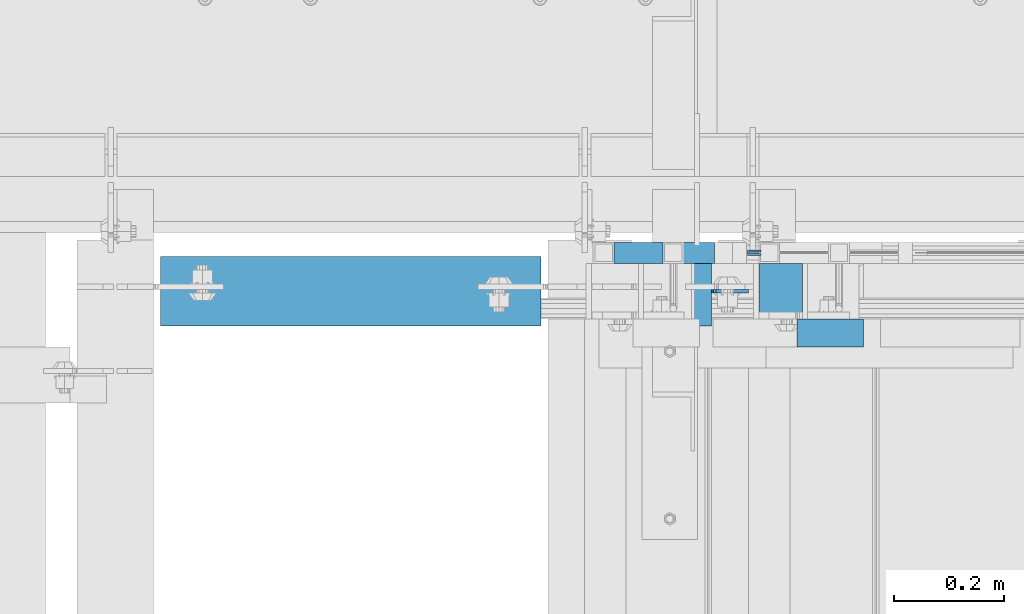
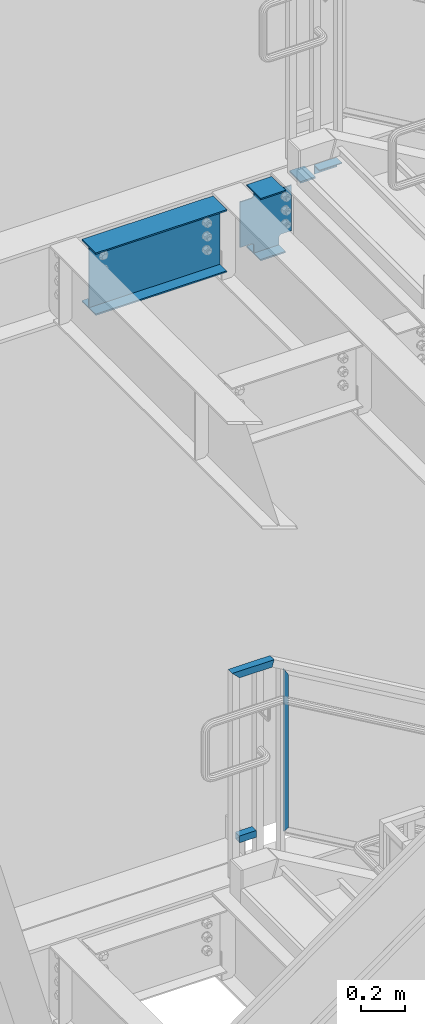
# One storey, part 934 of 1179: 5 beams, 2 members, 4 elements without a shape of their own.
"""IFC2X3 building model written with IfcOpenShell, lengths in millimetres."""

import ifcopenshell
import ifcopenshell.guid

model = None  # the IFC model being written
_history = None  # IfcOwnerHistory: only IFC2X3 demands one
_inside = {}  # id of a spatial element -> (the spatial element, [elements in it])
_under = {}  # id of a project, library or spatial element -> (it, [spatial elements below it])
_declared = {}  # id of a project -> (the project, [libraries it declares])
_typed = {}  # id of a type object -> (the type object, [elements of that type])
_made_of = {}  # id of a material, layer set ... -> (it, [elements and type objects made of it])


def new_model(schema):
    """Start an empty IFC model of exactly this schema.

    Asked for "IFC4X3", IfcOpenShell would pick the latest addendum, in which some entities
    have other attributes; the version numbers below select the first issue.
    IFC2X3 requires an IfcOwnerHistory on every rooted entity: one is made here for all.
    """
    global model, _history
    if schema == "IFC4X3":
        model = ifcopenshell.file(schema_version=(4, 3, 0, 0))
    else:
        model = ifcopenshell.file(schema=schema)
    _inside.clear()
    _under.clear()
    _declared.clear()
    _typed.clear()
    _made_of.clear()
    _history = None
    if model.schema == "IFC2X3":
        org = make("IfcOrganization", Name="unknown")
        user = make(
            "IfcPersonAndOrganization",
            ThePerson=make("IfcPerson", FamilyName="unknown"),
            TheOrganization=org,
        )
        app = make(
            "IfcApplication",
            ApplicationDeveloper=org,
            Version="unknown",
            ApplicationFullName="unknown",
            ApplicationIdentifier="unknown",
        )
        _history = make(
            "IfcOwnerHistory",
            OwningUser=user,
            OwningApplication=app,
            ChangeAction="ADDED",
            CreationDate=0,
        )
    return model


def make(cls, **values):
    """One entity of the class cls with the attributes given. An attribute that is None is left unset."""
    return model.create_entity(
        cls, **{name: value for name, value in values.items() if value is not None}
    )


def rooted(cls, **values):
    """An entity with a GlobalId (a new one), such as an element, a storey or a relation."""
    return make(cls, GlobalId=ifcopenshell.guid.new(), OwnerHistory=_history, **values)


def si_unit(unit_type, name, prefix=None):
    """IfcSIUnit, for example si_unit("LENGTHUNIT", "METRE", prefix="MILLI")."""
    return make("IfcSIUnit", UnitType=unit_type, Prefix=prefix, Name=name)


def assignment(units):
    """IfcUnitAssignment: the units of a project."""
    return None if units is None else make("IfcUnitAssignment", Units=units)


def point(xyz):
    """IfcCartesianPoint."""
    return None if xyz is None else make("IfcCartesianPoint", Coordinates=xyz)


def direction(xyz):
    """IfcDirection."""
    return None if xyz is None else make("IfcDirection", DirectionRatios=xyz)


def frame(location, z_axis=None, x_axis=None):
    """IfcAxis2Placement3D, a coordinate frame: its origin and axes. An axis left out is left unset."""
    return make(
        "IfcAxis2Placement3D",
        Location=point(location),
        Axis=direction(z_axis),
        RefDirection=direction(x_axis),
    )


def origin_with_axes():
    """The frame at (0, 0, 0) with the z axis (0, 0, 1) and the x axis (1, 0, 0) written out."""
    return frame((0.0, 0.0, 0.0), z_axis=(0.0, 0.0, 1.0), x_axis=(1.0, 0.0, 0.0))


def place(relative_to, where):
    """IfcLocalPlacement: puts the frame where relative to a parent placement (None: the world)."""
    return make(
        "IfcLocalPlacement", PlacementRelTo=relative_to, RelativePlacement=where
    )


def context(
    kind, dimensions, precision=None, world=None, true_north=None, identifier=None
):
    """IfcGeometricRepresentationContext, for example the 3D "Model" context."""
    return make(
        "IfcGeometricRepresentationContext",
        ContextIdentifier=identifier,
        ContextType=kind,
        CoordinateSpaceDimension=dimensions,
        Precision=precision,
        WorldCoordinateSystem=world,
        TrueNorth=true_north,
    )


def subcontext(parent, identifier, kind, view, scale=None):
    """IfcGeometricRepresentationSubContext, for example "Body" below "Model"."""
    return make(
        "IfcGeometricRepresentationSubContext",
        ContextIdentifier=identifier,
        ContextType=kind,
        ParentContext=parent,
        TargetScale=scale,
        TargetView=view,
    )


def project(units=None, contexts=None):
    """IfcProject with its units and contexts."""
    return rooted(
        "IfcProject",
        Name="project",
        RepresentationContexts=contexts,
        UnitsInContext=assignment(units),
    )


def spatial(cls, under=None, at=None, **own):
    """A site, building, storey or space (cls), placed at a placement, below another one or the project."""
    s = rooted(cls, ObjectPlacement=at, **own)
    if under is not None:
        _under.setdefault(under.id(), (under, []))[1].append(s)
    return s


def faces_of(points, faces, orient=None, outer=None):
    """IfcFace entities. A face is a list of loops; a loop is a list of indices into points, from 0.

    orient and outer hold one flag for each loop. By default every Orientation is true, the
    first loop of a face is its IfcFaceOuterBound and the others are IfcFaceBound.
    """
    made = []
    for i, loops in enumerate(faces):
        bounds = []
        for j, loop in enumerate(loops):
            is_outer = j == 0 if outer is None else outer[i][j]
            bounds.append(
                make(
                    "IfcFaceOuterBound" if is_outer else "IfcFaceBound",
                    Bound=make("IfcPolyLoop", Polygon=[points[k] for k in loop]),
                    Orientation=True if orient is None else orient[i][j],
                )
            )
        made.append(make("IfcFace", Bounds=bounds))
    return made


def faceted_brep(points, faces, orient=None, outer=None, voids=None):
    """IfcFacetedBrep: a solid bounded by flat faces; with voids (closed shells), ...WithVoids."""
    shared = [point(p) for p in points]
    hull = make("IfcClosedShell", CfsFaces=faces_of(shared, faces, orient, outer))
    if voids is None:
        return make("IfcFacetedBrep", Outer=hull)
    return make(
        "IfcFacetedBrepWithVoids",
        Outer=hull,
        Voids=[
            make(cls, CfsFaces=faces_of(shared, fs, o, b)) for cls, fs, o, b in voids
        ],
    )


def shape(context_of_items, identifier, shape_type, items):
    """IfcShapeRepresentation: the items that make up one representation, for example the "Body"."""
    return make(
        "IfcShapeRepresentation",
        ContextOfItems=context_of_items,
        RepresentationIdentifier=identifier,
        RepresentationType=shape_type,
        Items=items,
    )


def material(Name=None, Category=None):
    """IfcMaterial."""
    return make("IfcMaterial", Name=Name, Category=Category)


def made_of(thing, what):
    """Note that an element or type object is made of a material, layer set ...; save() writes the relation."""
    if what is not None:
        _made_of.setdefault(what.id(), (what, []))[1].append(thing)
    return thing


def type_object(cls, material=None, **own):
    """A type object (cls), such as IfcWallType, which elements share."""
    return made_of(rooted(cls, **own), material)


def element(
    cls,
    number,
    at=None,
    inside=None,
    cuts=None,
    type_object=None,
    material=None,
    context=None,
    identifier="Body",
    shape_type=None,
    held_by="IfcProductDefinitionShape",
    body=None,
    shapes=None,
    **own,
):
    """One element of the class cls, such as IfcWall. Its Tag is "e" and its number.

    at: its placement. inside: the storey or other place that contains it. cuts: it is an
    opening in that element (IfcRelVoidsElement). A single representation is given by context,
    identifier, shape_type and body (its items); several are given by shapes. held_by: the class
    of the entity that holds the representations. save() writes the other relations.
    """
    e = rooted(cls, Tag="e%d" % number, ObjectPlacement=at, **own)
    if body is not None:
        shapes = [shape(context, identifier, shape_type, body)]
    if shapes is not None:
        e.Representation = make(held_by, Representations=shapes)
    if inside is not None:
        _inside.setdefault(inside.id(), (inside, []))[1].append(e)
    if cuts is not None:
        rooted(
            "IfcRelVoidsElement", RelatingBuildingElement=cuts, RelatedOpeningElement=e
        )
    if type_object is not None:
        _typed.setdefault(type_object.id(), (type_object, []))[1].append(e)
    return made_of(e, material)


def aggregate(whole, parts):
    """IfcRelAggregates: a whole, such as a stair, and the parts it consists of."""
    return rooted("IfcRelAggregates", RelatingObject=whole, RelatedObjects=parts)


def save(model, path):
    """Write the relations noted so far, then the file.

    IfcRelAggregates (storeys below a building ...), IfcRelContainedInSpatialStructure (elements
    in a storey), IfcRelDefinesByType, IfcRelAssociatesMaterial and IfcRelDeclares: one each for
    every whole, place, type object, material and project.
    """
    for whole, parts in _under.values():
        aggregate(whole, parts)
    for where, things in _inside.values():
        rooted(
            "IfcRelContainedInSpatialStructure",
            RelatedElements=things,
            RelatingStructure=where,
        )
    for kind, things in _typed.values():
        rooted("IfcRelDefinesByType", RelatedObjects=things, RelatingType=kind)
    for what, things in _made_of.values():
        rooted("IfcRelAssociatesMaterial", RelatedObjects=things, RelatingMaterial=what)
    for by, libraries in _declared.values():
        rooted("IfcRelDeclares", RelatingContext=by, RelatedDefinitions=libraries)
    model.write(path)


model = new_model("IFC2X3")

# Units and contexts
model_context = context("Model", 3, precision=1e-05, world=origin_with_axes())
body_context = subcontext(model_context, "Body", "Model", "MODEL_VIEW")
ifc_project = project(units=[si_unit("LENGTHUNIT", "METRE", prefix="MILLI"), si_unit("AREAUNIT", "SQUARE_METRE"), si_unit("VOLUMEUNIT", "CUBIC_METRE"), si_unit("MASSUNIT", "GRAM", prefix="KILO"), si_unit("TIMEUNIT", "SECOND"), si_unit("PLANEANGLEUNIT", "RADIAN"), si_unit("SOLIDANGLEUNIT", "STERADIAN"), si_unit("THERMODYNAMICTEMPERATUREUNIT", "DEGREE_CELSIUS"), si_unit("LUMINOUSINTENSITYUNIT", "LUMEN")], contexts=[model_context])

# Site, building, storey
site_placement = place(None, origin_with_axes())
site = spatial("IfcSite", under=ifc_project, at=site_placement, CompositionType="ELEMENT")
building_placement = place(site_placement, origin_with_axes())
building = spatial("IfcBuilding", under=site, at=building_placement, Name="Undefined", CompositionType="ELEMENT")
storey_placement = place(building_placement, origin_with_axes())
storey = spatial("IfcBuildingStorey", under=building, at=storey_placement, Name="Undefined", CompositionType="ELEMENT", Elevation=0.0)

# Assembly, beam, members
assembly_1_placement = place(storey_placement, origin_with_axes())
assembly_1 = element("IfcElementAssembly", 1, at=assembly_1_placement, inside=storey, Name="GUARDRAIL", AssemblyPlace="NOTDEFINED", PredefinedType="RIGID_FRAME")
ifc_material_1 = material(Name="STEEL/BUY-OUT")
beam_type_1 = type_object("IfcBeamType", PredefinedType="NOTDEFINED")
beam_1_placement = place(assembly_1_placement, frame((19591.0331071758, 41062.2751647691, 4786.47180551808), z_axis=(0.0, 0.0, -1.0), x_axis=(-1.0, 0.0, 0.0)))
beam_1 = element("IfcBeam", 2, at=beam_1_placement, type_object=beam_type_1, material=ifc_material_1, Name="U-EDGE", context=body_context, shape_type="Brep", body=[
    faceted_brep([(2.91038304567337e-11, 7.9375, 440.175302877862), (25.3999999999687, 7.9375, 454.819), (25.400000000016, 7.9375, -454.819), (2.91038304567337e-11, 7.9375, -410.76229705665), (2.91038304567337e-11, 4.76249999999709, 440.175302877862), (2.91038304567337e-11, 4.76249999999709, -410.76229705665), (22.2250000000131, 4.76249999999709, 452.988538277322), (22.2250000000131, 4.76249999999709, -449.311912132071), (22.2250000000131, 1.58750000000146, 452.988538277322), (22.2250000000131, 1.58750000000146, -449.311912132071), (0.0, 1.58750000000146, 440.175302877845), (0.0, 1.58750000000146, -410.7622970566), (0.0, -1.58750000000146, 440.175302877845), (0.0, -1.58750000000146, -410.7622970566), (25.3999999999687, -1.58750000000146, 454.819), (25.400000000016, -1.58750000000146, -454.819)], [[[0, 1, 2, 3]], [[4, 0, 3, 5]], [[6, 4, 5, 7]], [[8, 6, 7, 9]], [[10, 8, 9, 11]], [[12, 10, 11, 13]], [[14, 12, 13, 15]], [[11, 9, 7, 5, 3, 2, 15, 13]], [[1, 14, 15, 2]], [[0, 4, 6, 8, 10, 12, 14, 1]]]),
])
ifc_material_2 = material()
member_type = type_object("IfcMemberType", Name="HSS1-1/2X1-1/2X1/8", PredefinedType="NOTDEFINED")
member_1_placement = place(assembly_1_placement, frame((19304.0000001842, 41065.4499993604, 4381.49999864483), z_axis=(0.0, -1.0, 0.0), x_axis=(1.0, 0.0, 0.0)))
member_1 = element("IfcMember", 3, at=member_1_placement, type_object=member_type, material=ifc_material_2, Name="BOTTOM_RAIL", ObjectType="HSS1-1/2X1-1/2X1/8", context=body_context, shape_type="Brep", body=[
    faceted_brep([(107.950001301364, -19.0499992349942, 19.0499992350015), (107.950001301364, -19.0499992349942, -19.0499992350015), (107.949999235003, 19.0499992349996, -19.0499992350015), (107.949999235003, 19.0499992349996, 19.0499992350015), (107.950001288671, -15.8749992829944, 15.874999282998), (107.950001161731, 15.8749992830053, 15.874999282998), (107.950001161731, 15.8749992830053, -15.874999282998), (107.950001288671, -15.8749992829944, -15.874999282998), (19.0499999999993, 19.0499992349996, -19.0499992350015), (19.0499999999993, 19.0499992349996, 19.0499992350015), (19.0499999999993, -19.0499992349996, 19.0500001223481), (19.0499999999993, -19.0499992349996, -19.0499992350015), (19.0499999999993, -15.8749992829999, 15.874999282998), (19.0499999999993, -15.8749992829999, -15.874999282998), (19.0499999999993, 15.8749992829999, -15.874999282998), (19.0499999999993, 15.8749992829999, 15.874999282998)], [[[0, 1, 2, 3], [4, 5, 6, 7]], [[3, 2, 8, 9]], [[9, 10, 0, 3]], [[10, 11, 1, 0]], [[11, 8, 2, 1]], [[10, 9, 8, 11], [12, 13, 14, 15]], [[13, 12, 4, 7]], [[14, 13, 7, 6]], [[15, 14, 6, 5]], [[12, 15, 5, 4]]]),
])
member_2_placement = place(assembly_1_placement, frame((19303.9999999845, 41065.4499993604, 5302.25), z_axis=(0.0, 0.0, 1.0), x_axis=(1.0, 0.0, 0.0)))
member_2 = element("IfcMember", 4, at=member_2_placement, type_object=member_type, material=ifc_material_2, Name="TOP_RAIL", ObjectType="HSS1-1/2X1-1/2X1/8", context=body_context, shape_type="Brep", body=[
    faceted_brep([(15.874999282998, 15.874999282998, -15.8749992829999), (15.874999282998, -15.874999282998, -15.8749992829999), (192.585831865978, -15.874999282998, -15.8749992829999), (192.585831865978, 15.874999282998, -15.8749992829999), (-15.8749992830017, -15.874999282998, 15.8749992829999), (201.114170631146, -15.874999282998, 15.8749992829999), (-15.8749992830017, 15.874999282998, 15.8749992829999), (201.114170631146, 15.874999282998, 15.8749992829999), (19.0499999999993, 19.0499992349996, -19.0499992350015), (-19.0499992350015, 19.0499992350015, 19.0499992349996), (201.96700453329, 19.0499992350015, 19.0499992349996), (191.732997963838, 19.0499992350015, -19.0499992349996), (-19.0499992350015, -19.0499992350015, 19.0499992349996), (201.96700453329, -19.0499992350015, 19.0499992349996), (19.0499999999993, -19.0499992349996, -19.0499992350015), (191.732997963838, -19.0499992350015, -19.0499992349996)], [[[0, 1, 2, 3]], [[1, 4, 5, 2]], [[4, 6, 7, 5]], [[6, 0, 3, 7]], [[8, 9, 10, 11]], [[9, 12, 13, 10]], [[12, 14, 15, 13]], [[14, 8, 11, 15]], [[13, 15, 11, 10], [5, 7, 3, 2]], [[14, 12, 9, 8], [6, 4, 1, 0]]]),
])
aggregate(assembly_1, [beam_1, member_1, member_2])

# Assembly, beams
assembly_2_placement = place(storey_placement, origin_with_axes())
assembly_2 = element("IfcElementAssembly", 5, at=assembly_2_placement, inside=storey, Name="STAIR", AssemblyPlace="NOTDEFINED", PredefinedType="RIGID_FRAME")
ifc_material_3 = material(Name="STEEL/A36")
beam_type_2 = type_object("IfcBeamType", Name="L2X2X3/16", PredefinedType="NOTDEFINED")
beam_2_placement = place(assembly_2_placement, frame((19777.075064643, 40919.4000000076, 8068.27030705443), z_axis=(2.54499999937252e-06, 0.0, -0.999999999996761), x_axis=(-0.999999999996761, 0.0, -2.5449999982255e-06)))
beam_2 = element("IfcBeam", 6, at=beam_2_placement, type_object=beam_type_2, material=ifc_material_3, Name="ANGLE", ObjectType="L2X2X3/16", context=body_context, shape_type="Brep", body=[
    faceted_brep([(0.0, 25.3999999999996, -25.4000000000015), (0.0, 25.3999999999996, 25.4000000000015), (120.650000000842, 25.3999999999996, 25.4000000000015), (120.650000000842, 25.3999999999996, -25.4000000000015), (0.0, 20.6374999999998, 25.4000000000015), (120.650000000842, 20.6374999999998, 25.4000000000015), (0.0, 20.6374999999998, -20.6374999999971), (120.650000000842, 20.6374999999998, -20.6374999999971), (0.0, -25.3999999999996, -20.6374999999971), (120.650000000842, -25.3999999999996, -20.6374999999971), (0.0, -25.3999999999996, -25.4000000000015), (120.650000000842, -25.3999999999996, -25.4000000000015)], [[[0, 1, 2, 3]], [[1, 4, 5, 2]], [[4, 6, 7, 5]], [[6, 8, 9, 7]], [[8, 10, 11, 9]], [[10, 0, 3, 11]], [[5, 7, 9, 11, 3, 2]], [[10, 8, 6, 4, 1, 0]]]),
])
beam_type_3 = type_object("IfcBeamType", PredefinedType="NOTDEFINED")
beam_3_placement = place(assembly_2_placement, frame((19665.9499873571, 40995.6000000054, 8018.46249982855), z_axis=(0.0, -1.0, 0.0), x_axis=(-1.0, 0.0, 0.0)))
beam_3 = element("IfcBeam", 7, at=beam_3_placement, type_object=beam_type_3, material=ifc_material_3, Name="PLATE", context=body_context, shape_type="Brep", body=[
    faceted_brep([(0.0, 4.76249999999982, -50.7999999999993), (0.0, 4.76249999999982, 50.7999999999993), (79.3749874406894, 4.76250000000073, 50.8000000000029), (79.3749874406894, 4.76250000000073, -50.8000000000029), (0.0, -4.76249999999982, 50.7999999999993), (79.3749874406822, -4.76249999999982, 50.8000000000029), (0.0, -4.76249999999982, -50.7999999999993), (79.3749874406822, -4.76249999999982, -50.8000000000029)], [[[0, 1, 2, 3]], [[1, 4, 5, 2]], [[4, 6, 7, 5]], [[6, 0, 3, 7]], [[5, 7, 3, 2]], [[6, 4, 1, 0]]]),
])
aggregate(assembly_2, [beam_2, beam_3])

# Assembly, beam
assembly_3_placement = place(storey_placement, origin_with_axes())
assembly_3 = element("IfcElementAssembly", 8, at=assembly_3_placement, inside=storey, Name="BEAM", AssemblyPlace="NOTDEFINED", PredefinedType="RIGID_FRAME")
ifc_material_4 = material(Name="STEEL/A992")
beam_type_4 = type_object("IfcBeamType", Name="W14X22", PredefinedType="NOTDEFINED")
beam_4_placement = place(assembly_3_placement, frame((19278.6, 40995.5999999803, 7839.075), z_axis=(0.0, 0.0, 1.0), x_axis=(1.0, 0.0, 0.0)))
beam_4 = element("IfcBeam", 9, at=beam_4_placement, type_object=beam_type_4, material=ifc_material_4, Name="BEAM", ObjectType="W14X22", context=body_context, shape_type="Brep", body=[
    faceted_brep([(222.25, -3.17500000000291, -166.6875), (222.25, -63.5, -166.6875), (222.25, -63.5, -174.625), (222.25, 63.5, -174.625), (222.25, 63.5, -166.6875), (222.25, 3.17500000000291, -166.6875), (222.25, 3.17500000000291, -123.824999809265), (222.25, -3.17500000000291, -123.824999809265), (223.216729922588, 3.17500000000291, -118.96492029122), (223.216729922588, -3.17500000000291, -118.96492029122), (225.969743823065, 3.17500000000291, -114.844743823066), (225.969743823065, -3.17500000000291, -114.844743823066), (230.089920291219, 3.17500000000291, -112.091729922588), (230.089920291219, -3.17500000000291, -112.091729922588), (234.949999809265, 3.17500000000291, -111.125), (234.949999809265, -3.17500000000291, -111.125), (288.924999999999, -3.17500000000291, -111.125), (288.924999999999, 3.17500000000291, -111.125), (89.6937500000022, 3.17500000000291, 166.6875), (89.6937500000022, 63.5, 166.6875), (222.25, 63.5, 166.6875), (222.25, 3.17500000000291, 166.6875), (89.6937500000022, -3.17500000000291, -123.824999809265), (89.6937500000022, 3.17500000000291, -123.824999809265), (89.6937500000022, 3.17500000000291, -166.6875), (89.6937500000022, 63.5, -166.6875), (89.6937500000022, 63.5, -174.625), (89.6937500000022, -63.5, -174.625), (89.6937500000022, -63.5, -166.6875), (89.6937500000022, -3.17500000000291, -166.6875), (88.7270200774146, -3.17500000000291, -118.96492029122), (88.7270200774146, 3.17500000000291, -118.96492029122), (85.9740061769371, -3.17500000000291, -114.844743823066), (85.9740061769371, 3.17500000000291, -114.844743823066), (81.8538297087835, -3.17500000000291, -112.091729922588), (81.8538297087835, 3.17500000000291, -112.091729922588), (76.993750190737, -3.17500000000291, -111.125), (76.993750190737, 3.17500000000291, -111.125), (16.6687500000007, -3.17500000000291, -111.125), (16.6687500000007, 3.17500000000291, -111.125), (16.6687500000007, -3.17500000000291, 142.875), (16.6687500000007, 3.17500000000291, 142.875), (76.993750190737, -3.17500000000291, 142.875), (76.993750190737, 3.17500000000291, 142.875), (81.8538297087835, -3.17500000000291, 143.841729922588), (81.8538297087835, 3.17500000000291, 143.841729922588), (85.9740061769371, -3.17500000000291, 146.594743823066), (85.9740061769371, 3.17500000000291, 146.594743823066), (88.7270200774146, -3.17500000000291, 150.71492029122), (88.7270200774146, 3.17500000000291, 150.71492029122), (89.6937500000022, -3.17500000000291, 155.574999809265), (89.6937500000022, 3.17500000000291, 155.574999809265), (89.6937500000022, -63.5, 174.625), (89.6937500000022, 63.5, 174.625), (89.6937500000022, -3.17500000000291, 166.6875), (89.6937500000022, -63.5, 166.6875), (222.25, -3.17500000000291, 166.6875), (222.25, -63.5, 166.6875), (222.25, -63.5, 174.625), (222.25, 63.5, 174.625), (222.25, -3.17500000000291, 155.574999809265), (222.25, 3.17500000000291, 155.574999809265), (223.216729922588, -3.17500000000291, 150.71492029122), (223.216729922588, 3.17500000000291, 150.71492029122), (225.969743823065, -3.17500000000291, 146.594743823066), (225.969743823065, 3.17500000000291, 146.594743823066), (230.089920291219, -3.17500000000291, 143.841729922588), (230.089920291219, 3.17500000000291, 143.841729922588), (234.949999809265, -3.17500000000291, 142.875), (234.949999809265, 3.17500000000291, 142.875), (288.924999999999, -3.17500000000291, 142.875), (288.924999999999, 3.17500000000291, 142.875)], [[[0, 1, 2, 3, 4, 5, 6, 7]], [[7, 6, 8, 9]], [[9, 8, 10, 11]], [[11, 10, 12, 13]], [[13, 12, 14, 15]], [[16, 15, 14, 17]], [[18, 19, 20, 21]], [[22, 23, 24, 25, 26, 27, 28, 29]], [[30, 31, 23, 22]], [[32, 33, 31, 30]], [[34, 35, 33, 32]], [[36, 37, 35, 34]], [[38, 39, 37, 36]], [[40, 41, 39, 38]], [[42, 43, 41, 40]], [[44, 45, 43, 42]], [[46, 47, 45, 44]], [[48, 49, 47, 46]], [[50, 51, 49, 48]], [[52, 53, 19, 18, 51, 50, 54, 55]], [[55, 54, 56, 57]], [[52, 55, 57, 58]], [[53, 52, 58, 59]], [[19, 53, 59, 20]], [[58, 57, 56, 60, 61, 21, 20, 59]], [[62, 63, 61, 60]], [[64, 65, 63, 62]], [[66, 67, 65, 64]], [[68, 69, 67, 66]], [[70, 71, 69, 68]], [[71, 70, 16, 17]], [[12, 10, 8, 6, 5, 24, 23, 31, 33, 35, 37, 39, 41, 43, 45, 47, 49, 51, 18, 21, 61, 63, 65, 67, 69, 71, 17, 14]], [[25, 24, 5, 4]], [[26, 25, 4, 3]], [[27, 26, 3, 2]], [[28, 27, 2, 1]], [[29, 28, 1, 0]], [[70, 68, 66, 64, 62, 60, 56, 54, 50, 48, 46, 44, 42, 40, 38, 36, 34, 32, 30, 22, 29, 0, 7, 9, 11, 13, 15, 16]]]),
])
aggregate(assembly_3, [beam_4])

assembly_4_placement = place(storey_placement, origin_with_axes())
assembly_4 = element("IfcElementAssembly", 10, at=assembly_4_placement, inside=storey, Name="BEAM", AssemblyPlace="NOTDEFINED", PredefinedType="RIGID_FRAME")
beam_5_placement = place(assembly_4_placement, frame((18415.0, 40995.5999999803, 7839.075), z_axis=(0.0, 0.0, 1.0), x_axis=(1.0, 0.0, 0.0)))
beam_5 = element("IfcBeam", 11, at=beam_5_placement, type_object=beam_type_4, material=ifc_material_4, Name="BEAM", ObjectType="W14X22", context=body_context, shape_type="Brep", body=[
    faceted_brep([(82.5499999999993, -63.5, -174.625), (82.5499999999993, 63.5, -174.625), (774.700000000001, 63.5, -174.625), (774.700000000001, -63.5, -174.625), (82.5499999999993, -63.5, -166.6875), (82.5499999999993, -3.17500000000291, -166.6875), (82.5499999999993, -3.17500000000291, 166.6875), (82.5499999999993, -63.5, 166.6875), (82.5499999999993, -63.5, 174.625), (82.5499999999993, 63.5, 174.625), (82.5499999999993, 63.5, 166.6875), (82.5499999999993, 3.17500000000291, 166.6875), (82.5499999999993, 3.17500000000291, 137.265000000114), (82.5499999999993, 3.17500000000291, -92.8149999999623), (82.5499999999993, 3.17500000000291, -166.6875), (82.5499999999993, 63.5, -166.6875), (774.700000000001, -63.5, -166.6875), (774.700000000001, -3.17500000000291, -166.6875), (774.700000000001, -3.17500000000291, 166.6875), (774.700000000001, -63.5, 166.6875), (774.700000000001, -63.5, 174.625), (774.700000000001, 63.5, 174.625), (774.700000000001, 63.5, 166.6875), (774.700000000001, 3.17500000000291, 166.6875), (774.700000000001, 3.17500000000291, 137.265000000132), (774.700000000001, 3.17500000000291, -92.8149999999441), (774.700000000001, 3.17500000000291, -166.6875), (774.700000000001, 63.5, -166.6875)], [[[0, 1, 2, 3]], [[0, 4, 5, 6, 7, 8, 9, 10, 11, 12, 13, 14, 15, 1]], [[5, 4, 16, 17]], [[6, 5, 17, 18]], [[7, 6, 18, 19]], [[8, 7, 19, 20]], [[9, 8, 20, 21]], [[10, 9, 21, 22]], [[11, 10, 22, 23]], [[14, 13, 12, 11, 23, 24, 25, 26]], [[15, 14, 26, 27]], [[1, 15, 27, 2]], [[26, 25, 24, 23, 22, 21, 20, 19, 18, 17, 16, 3, 2, 27]], [[4, 0, 3, 16]]]),
])
aggregate(assembly_4, [beam_5])

save(model, "model.ifc")
